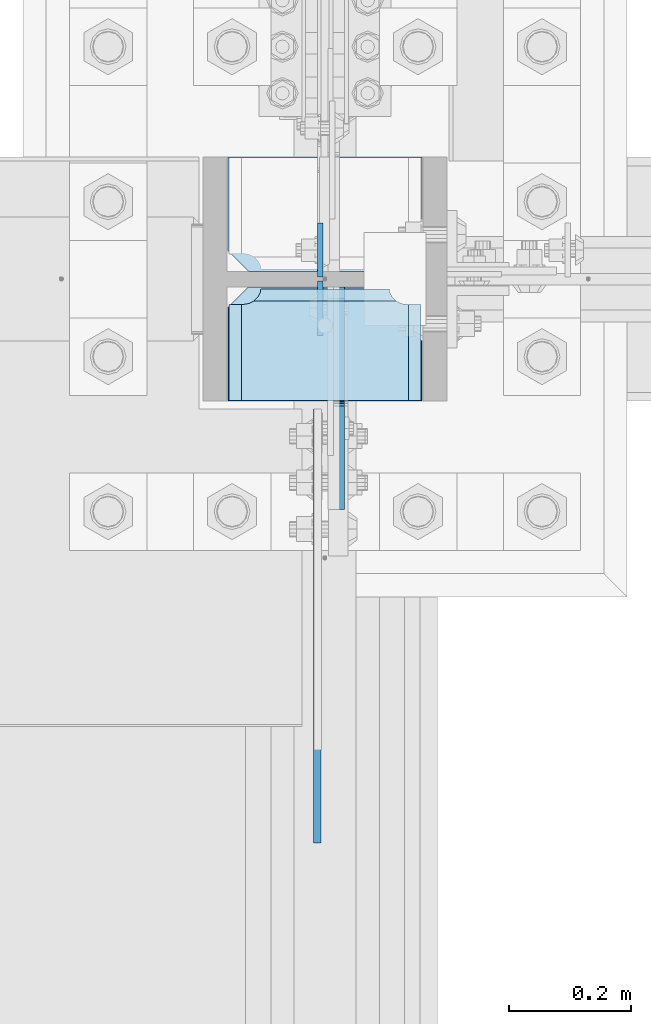
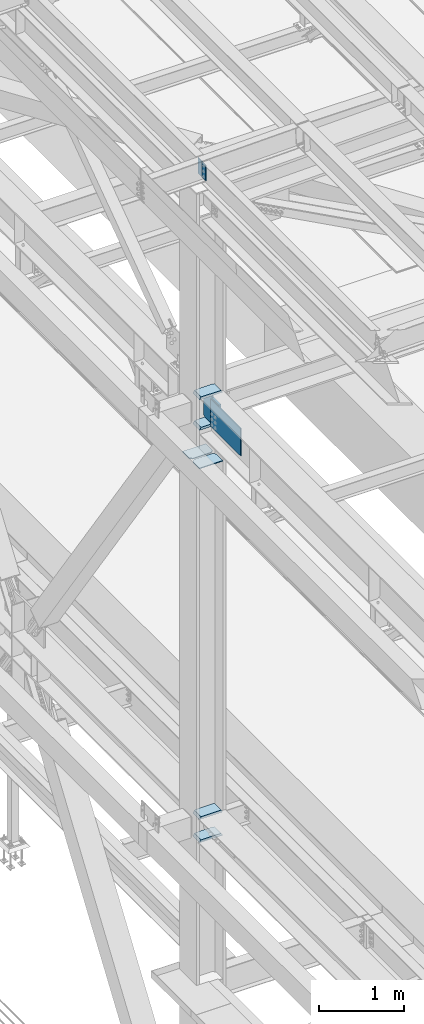
# One storey, part 3248 of 3843: 10 plates, 3 elements without a shape of their own.
"""IFC2X3 building model written with IfcOpenShell, lengths in millimetres."""

from ifc_helpers import new_model, si_unit, frame, origin_with_axes, place, context, subcontext, project, spatial, faceted_brep, material, type_object, element, aggregate, save


model = new_model("IFC2X3")

# Units and contexts
model_context = context("Model", 3, precision=1e-05, world=origin_with_axes())
body_context = subcontext(model_context, "Body", "Model", "MODEL_VIEW")
ifc_project = project(units=[si_unit("LENGTHUNIT", "METRE", prefix="MILLI"), si_unit("AREAUNIT", "SQUARE_METRE"), si_unit("VOLUMEUNIT", "CUBIC_METRE"), si_unit("MASSUNIT", "GRAM", prefix="KILO"), si_unit("TIMEUNIT", "SECOND"), si_unit("PLANEANGLEUNIT", "RADIAN"), si_unit("SOLIDANGLEUNIT", "STERADIAN"), si_unit("THERMODYNAMICTEMPERATUREUNIT", "DEGREE_CELSIUS"), si_unit("LUMINOUSINTENSITYUNIT", "LUMEN")], contexts=[model_context])

# Site, building, storey
site_placement = place(None, origin_with_axes())
site = spatial("IfcSite", under=ifc_project, at=site_placement, CompositionType="ELEMENT")
building_placement = place(site_placement, origin_with_axes())
building = spatial("IfcBuilding", under=site, at=building_placement, Name="Undefined", CompositionType="ELEMENT")
storey_placement = place(building_placement, origin_with_axes())
storey = spatial("IfcBuildingStorey", under=building, at=storey_placement, Name="Undefined", CompositionType="ELEMENT", Elevation=0.0)

# Assembly, plates
assembly_1_placement = place(storey_placement, origin_with_axes())
assembly_1 = element("IfcElementAssembly", 1, at=assembly_1_placement, inside=storey, Name="BEAM", AssemblyPlace="NOTDEFINED", PredefinedType="RIGID_FRAME")
ifc_material = material(Name="STEEL/A572-50")
plate_type_1 = type_object("IfcPlateType", PredefinedType="NOTDEFINED")
plate_1_placement = place(assembly_1_placement, frame((36568.0624999422, 50561.875, 45691.494629366), z_axis=(0.0, 1.0, 0.0), x_axis=(0.0, 0.0, -1.0)))
plate_1 = element("IfcPlate", 2, at=plate_1_placement, type_object=plate_type_1, material=ifc_material, Name="PLATE", context=body_context, shape_type="Brep", body=[
    faceted_brep([(0.0, -4.76249999999709, 0.0), (0.0, -4.76249999999709, 88.9000015258789), (0.0, 4.76249999999709, 88.9000015258789), (0.0, 4.76249999999709, 0.0), (228.600006102781, -4.7625000004191, 88.9000015257589), (228.600006102781, 4.76249999954598, 88.9000015257443), (228.600006103079, -4.7625000004482, 7.27595761418343e-12), (228.600006103079, 4.76249999954598, -7.27595761418343e-12)], [[[0, 1, 2, 3]], [[1, 4, 5, 2]], [[4, 6, 7, 5]], [[6, 0, 3, 7]], [[5, 7, 3, 2]], [[6, 4, 1, 0]]]),
])
plate_2_placement = place(assembly_1_placement, frame((36568.0624999363, 50555.525, 45691.494629366), z_axis=(0.0, -1.0, 0.0), x_axis=(0.0, 0.0, -1.0)))
plate_2 = element("IfcPlate", 3, at=plate_2_placement, type_object=plate_type_1, material=ifc_material, Name="PLATE", context=body_context, shape_type="Brep", body=[
    faceted_brep([(0.0, -4.76249999999709, 0.0), (0.0, -4.76249999999709, 88.9000015258789), (0.0, 4.76249999999709, 88.9000015258789), (0.0, 4.76249999999709, 0.0), (228.600006102781, -4.7625000004191, 88.9000015257589), (228.600006102781, 4.76249999954598, 88.9000015257443), (228.600006103079, -4.7625000004482, 7.27595761418343e-12), (228.600006103079, 4.76249999954598, -7.27595761418343e-12)], [[[0, 1, 2, 3]], [[1, 4, 5, 2]], [[4, 6, 7, 5]], [[6, 0, 3, 7]], [[5, 7, 3, 2]], [[6, 4, 1, 0]]]),
])
aggregate(assembly_1, [plate_1, plate_2])

assembly_2_placement = place(storey_placement, origin_with_axes())
assembly_2 = element("IfcElementAssembly", 4, at=assembly_2_placement, inside=storey, Name="COLUMN", AssemblyPlace="NOTDEFINED", PredefinedType="RIGID_FRAME")
plate_type_2 = type_object("IfcPlateType", PredefinedType="NOTDEFINED")
plate_3_placement = place(assembly_2_placement, frame((36595.0500001907, 50546.0, 42049.7), z_axis=(0.0, -0.707106781186682, 0.707106781186413), x_axis=(0.0, -0.707106781186548, -0.707106781186548)))
plate_3 = element("IfcPlate", 5, at=plate_3_placement, type_object=plate_type_2, material=ifc_material, Name="PLATE", context=body_context, shape_type="Brep", body=[
    faceted_brep([(0.0, -12.6999999999971, 0.0), (-258.182363479558, -12.6999999999971, 258.182363479453), (-258.182363479558, 12.6999999999971, 258.182363479453), (0.0, 12.6999999999971, 0.0), (-258.182363479282, -12.6999999999971, 285.123131842804), (-258.182363479282, 12.6999999999971, 285.123131842804), (-139.193969873246, -12.6999999999971, 404.111525448876), (-139.193969873246, 12.6999999999971, 404.111525448876), (-132.458777647626, -12.6999999999971, 397.376333223259), (-132.458777647626, 12.6999999999971, 397.376333223259), (-128.338601179479, -12.6999999999971, 394.623319322793), (-128.338601179479, 12.6999999999971, 394.623319322793), (-123.478521661425, -12.6999999999971, 393.656589400227), (-123.478521661425, 12.6999999999971, 393.656589400227), (-118.618442143357, -12.6999999999971, 394.623319322851), (-118.618442143357, 12.6999999999971, 394.623319322851), (-114.498265675167, -12.6999999999971, 397.376333223354), (-114.498265675167, 12.6999999999971, 397.376333223354), (2.24506403549458, -12.6999999999971, 514.119662934059), (2.24506403549458, 12.6999999999971, 514.119662934059), (280.633003787327, -12.6999999999971, 235.731723182307), (280.633003787327, 12.6999999999971, 235.731723182307), (154.909418090407, -12.6999999999971, 110.008137485343), (154.909418090407, 12.6999999999971, 110.008137485343), (145.929161969383, -12.6999999999971, 118.98839360636), (145.929161969383, 12.6999999999971, 118.98839360636), (26.9407683630998, -12.7000000000007, 3.63797880709171e-12), (26.9407683630998, 12.7000000000007, 3.63797880709171e-12)], [[[0, 1, 2, 3]], [[1, 4, 5, 2]], [[4, 6, 7, 5]], [[6, 8, 9, 7]], [[8, 10, 11, 9]], [[10, 12, 13, 11]], [[12, 14, 15, 13]], [[14, 16, 17, 15]], [[16, 18, 19, 17]], [[18, 20, 21, 19]], [[20, 22, 23, 21]], [[22, 24, 25, 23]], [[24, 26, 27, 25]], [[26, 0, 3, 27]], [[5, 7, 9, 11, 13, 15, 17, 19, 21, 23, 25, 27, 3, 2]], [[26, 24, 22, 20, 18, 16, 14, 12, 10, 8, 6, 4, 1, 0]]]),
])
plate_type_3 = type_object("IfcPlateType", PredefinedType="NOTDEFINED")
plate_4_placement = place(assembly_2_placement, frame((36736.3375, 50546.0, 42013.1875), z_axis=(-1.0, 0.0, 0.0), x_axis=(0.0, -1.0, 0.0)))
plate_4 = element("IfcPlate", 6, at=plate_4_placement, type_object=plate_type_3, material=ifc_material, Name="PLATE", context=body_context, shape_type="Brep", body=[
    faceted_brep([(16.7959640327026, 6.12986484301655, 270.569839531447), (23.117661231503, 17.0792088240414, 276.89153673024), (23.3389576632762, 17.4625000000015, 277.325855432093), (23.3389576632762, 17.4625000000015, 43.3491445679101), (23.1176612314885, 17.0792088240414, 43.7834632697632), (16.7959640327026, 6.12986484301655, 50.1051604685563), (8.83016085001873, -7.66711346669035, 54.1639399157939), (3.17499995231628, -17.4625000000015, 55.059629409523), (3.17499995231628, -17.4625000000015, 265.61537059048), (8.83016085003328, -7.66711346669035, 266.511060084209), (28.5750007629395, 17.4625000000015, 297.336542336721), (28.5750007629395, -17.4625000000015, 317.500500047689), (186.531300000002, -17.4625000000015, 317.500500047689), (186.531300000002, 17.4625000000015, 297.336542336721), (186.531300000002, 17.4625000000015, 23.3384576632816), (186.531300000002, -17.4625000000015, 3.17449995231436), (28.5750007629395, -17.4625000000015, 3.17449995230709), (28.5750007629395, 17.4625000000015, 23.338457663267), (8.83016085001873, -17.4625000000015, 266.511047877182), (16.7959640327026, -17.4625000000015, 270.56982732442), (23.1176612314885, -17.4625000000015, 276.891524523206), (27.1764406787261, -17.4625000000015, 284.857327705889), (27.1764406787261, 17.4625000000015, 284.857327705889), (28.5750007629395, -17.4625000000015, 293.687488555908), (28.5750007629395, 17.4625000000015, 293.687488555908), (28.5750007629395, -17.4625000000015, 26.9874992370605), (28.5750007629395, 17.4625000000015, 26.9874992370605), (27.1764406787261, -17.4625000000015, 35.8176600870793), (27.1764406787261, 17.4625000000015, 35.8176600870793), (23.1176612314885, -17.4625000000015, 43.7834632697632), (16.7959640327026, -17.4625000000015, 50.105160468549), (8.83016085001873, -17.4625000000015, 54.1639399157866)], [[[0, 1, 2, 3, 4, 5, 6, 7, 8, 9]], [[10, 11, 12, 13]], [[14, 15, 16, 17]], [[18, 9, 8]], [[18, 19, 0, 9]], [[19, 20, 1, 0]], [[20, 21, 22, 2, 1]], [[21, 23, 24, 22]], [[24, 23, 11, 10]], [[15, 14, 13, 12]], [[25, 26, 17, 16]], [[25, 27, 28, 26]], [[28, 27, 29, 4, 3]], [[29, 30, 5, 4]], [[30, 31, 6, 5]], [[31, 7, 6]], [[22, 24, 10, 13, 14, 17, 26, 28, 3, 2]], [[31, 30, 29, 27, 25, 16, 15, 12, 11, 23, 21, 20, 19, 18, 8, 7]]]),
])
plate_5_placement = place(assembly_2_placement, frame((36736.3375, 50546.0, 42451.3375), z_axis=(-1.0, 0.0, 0.0), x_axis=(0.0, -1.0, 0.0)))
plate_5 = element("IfcPlate", 7, at=plate_5_placement, type_object=plate_type_3, material=ifc_material, Name="PLATE", context=body_context, shape_type="Brep", body=[
    faceted_brep([(16.7959640327026, 6.12954035346047, 270.569839531447), (23.117661231503, 17.0792088240414, 276.89153673024), (23.3389576632762, 17.4625000000015, 277.325855432093), (23.3389576632762, 17.4625000000015, 43.3491445679101), (23.1176612314885, 17.0792088240414, 43.7834632697632), (16.7959640327026, 6.12954035346047, 50.1051604685563), (8.83016085001873, -7.6678330078139, 54.1639399157939), (3.17499995231628, -17.4625000000015, 55.059629409523), (3.17499995231628, -17.4625000000015, 265.61537059048), (8.83016085003328, -7.6678330078139, 266.511060084209), (28.5750007629395, 17.4625000000015, 297.336542336721), (28.5750007629395, -17.4625000000015, 317.500500047689), (186.531300000002, -17.4625000000015, 317.500500047689), (186.531300000002, 17.4625000000015, 297.336542336721), (186.531300000002, 17.4625000000015, 23.3384576632816), (186.531300000002, -17.4625000000015, 3.17449995231436), (28.5750007629395, -17.4625000000015, 3.17449995230709), (28.5750007629395, 17.4625000000015, 23.338457663267), (8.83016085001873, -17.4625000000015, 266.511047877182), (16.7959640327026, -17.4625000000015, 270.56982732442), (23.1176612314885, -17.4625000000015, 276.891524523206), (27.1764406787261, -17.4625000000015, 284.857327705889), (27.1764406787261, 17.4625000000015, 284.857327705889), (28.5750007629395, -17.4625000000015, 293.687488555908), (28.5750007629395, 17.4625000000015, 293.687488555908), (28.5750007629395, -17.4625000000015, 26.9874992370605), (28.5750007629395, 17.4625000000015, 26.9874992370605), (27.1764406787261, -17.4625000000015, 35.8176600870793), (27.1764406787261, 17.4625000000015, 35.8176600870793), (23.1176612314885, -17.4625000000015, 43.7834632697632), (16.7959640327026, -17.4625000000015, 50.105160468549), (8.83016085001873, -17.4625000000015, 54.1639399157866)], [[[0, 1, 2, 3, 4, 5, 6, 7, 8, 9]], [[10, 11, 12, 13]], [[14, 15, 16, 17]], [[18, 9, 8]], [[18, 19, 0, 9]], [[19, 20, 1, 0]], [[20, 21, 22, 2, 1]], [[21, 23, 24, 22]], [[24, 23, 11, 10]], [[15, 14, 13, 12]], [[25, 26, 17, 16]], [[25, 27, 28, 26]], [[28, 27, 29, 4, 3]], [[29, 30, 5, 4]], [[30, 31, 6, 5]], [[31, 7, 6]], [[22, 24, 10, 13, 14, 17, 26, 28, 3, 2]], [[31, 30, 29, 27, 25, 16, 15, 12, 11, 23, 21, 20, 19, 18, 8, 7]]]),
])
plate_6_placement = place(assembly_2_placement, frame((36736.3375, 50546.0, 36085.4625), z_axis=(-1.0, 0.0, 0.0), x_axis=(0.0, -1.0, 0.0)))
plate_6 = element("IfcPlate", 8, at=plate_6_placement, type_object=plate_type_3, material=ifc_material, Name="PLATE", context=body_context, shape_type="Brep", body=[
    faceted_brep([(16.7959640327026, 6.1297025982276, 270.569839531447), (23.117661231503, 17.0792088240414, 276.89153673024), (23.3389576632762, 17.4625000000015, 277.325855432093), (23.3389576632762, 17.4625000000015, 43.3491445679101), (23.1176612314885, 17.0792088240414, 43.7834632697632), (16.7959640327026, 6.1297025982276, 50.1051604685563), (8.830160850026, -7.66747323726304, 54.1639399157939), (3.17499995231628, -17.4625000000015, 55.059629409523), (3.17499995231628, -17.4625000000015, 265.61537059048), (8.830160850026, -7.66747323726304, 266.511060084209), (186.531300000002, 17.4625000000015, 23.3384576632816), (186.531300000002, -17.4625000000015, 3.17449995231436), (28.5750007629395, -17.4625000000015, 3.17449995230709), (28.5750007629395, 17.4625000000015, 23.338457663267), (28.5750007629395, 17.4625000000015, 297.336542336721), (28.5750007629395, -17.4625000000015, 317.500500047689), (186.531300000002, -17.4625000000015, 317.500500047689), (186.531300000002, 17.4625000000015, 297.336542336721), (8.83016085001873, -17.4625000000015, 266.511047877182), (16.7959640327026, -17.4625000000015, 270.56982732442), (23.1176612314885, -17.4625000000015, 276.891524523206), (27.1764406787261, -17.4625000000015, 284.857327705889), (27.1764406787261, 17.4625000000015, 284.857327705889), (28.5750007629395, -17.4625000000015, 293.687488555908), (28.5750007629395, 17.4625000000015, 293.687488555908), (28.5750007629395, -17.4625000000015, 26.9874992370605), (28.5750007629395, 17.4625000000015, 26.9874992370605), (27.1764406787261, -17.4625000000015, 35.8176600870793), (27.1764406787261, 17.4625000000015, 35.8176600870793), (23.1176612314885, -17.4625000000015, 43.7834632697632), (16.7959640327026, -17.4625000000015, 50.105160468549), (8.83016085001873, -17.4625000000015, 54.1639399157866)], [[[0, 1, 2, 3, 4, 5, 6, 7, 8, 9]], [[10, 11, 12, 13]], [[14, 15, 16, 17]], [[18, 9, 8]], [[18, 19, 0, 9]], [[19, 20, 1, 0]], [[20, 21, 22, 2, 1]], [[21, 23, 24, 22]], [[24, 23, 15, 14]], [[11, 10, 17, 16]], [[25, 26, 13, 12]], [[25, 27, 28, 26]], [[28, 27, 29, 4, 3]], [[29, 30, 5, 4]], [[30, 31, 6, 5]], [[31, 7, 6]], [[22, 24, 14, 17, 10, 13, 26, 28, 3, 2]], [[31, 30, 29, 27, 25, 12, 11, 16, 15, 23, 21, 20, 19, 18, 8, 7]]]),
])
plate_7_placement = place(assembly_2_placement, frame((36736.3375, 50546.0, 36418.8375), z_axis=(-1.0, 0.0, 0.0), x_axis=(0.0, -1.0, 0.0)))
plate_7 = element("IfcPlate", 9, at=plate_7_placement, type_object=plate_type_3, material=ifc_material, Name="PLATE", context=body_context, shape_type="Brep", body=[
    faceted_brep([(16.7959640327026, 6.1297025982276, 270.569839531447), (23.117661231503, 17.0792088240414, 276.89153673024), (23.3389576632762, 17.4625000000015, 277.325855432093), (23.3389576632762, 17.4625000000015, 43.3491445679101), (23.1176612314885, 17.0792088240414, 43.7834632697632), (16.7959640327026, 6.1297025982276, 50.1051604685563), (8.830160850026, -7.66747323726304, 54.1639399157939), (3.17499995231628, -17.4625000000015, 55.059629409523), (3.17499995231628, -17.4625000000015, 265.61537059048), (8.830160850026, -7.66747323726304, 266.511060084209), (186.531300000002, 17.4625000000015, 23.3384576632816), (186.531300000002, -17.4625000000015, 3.17449995231436), (28.5750007629395, -17.4625000000015, 3.17449995230709), (28.5750007629395, 17.4625000000015, 23.338457663267), (28.5750007629395, 17.4625000000015, 297.336542336721), (28.5750007629395, -17.4625000000015, 317.500500047689), (186.531300000002, -17.4625000000015, 317.500500047689), (186.531300000002, 17.4625000000015, 297.336542336721), (8.83016085001873, -17.4625000000015, 266.511047877182), (16.7959640327026, -17.4625000000015, 270.56982732442), (23.1176612314885, -17.4625000000015, 276.891524523206), (27.1764406787261, -17.4625000000015, 284.857327705889), (27.1764406787261, 17.4625000000015, 284.857327705889), (28.5750007629395, -17.4625000000015, 293.687488555908), (28.5750007629395, 17.4625000000015, 293.687488555908), (28.5750007629395, -17.4625000000015, 26.9874992370605), (28.5750007629395, 17.4625000000015, 26.9874992370605), (27.1764406787261, -17.4625000000015, 35.8176600870793), (27.1764406787261, 17.4625000000015, 35.8176600870793), (23.1176612314885, -17.4625000000015, 43.7834632697632), (16.7959640327026, -17.4625000000015, 50.105160468549), (8.83016085001873, -17.4625000000015, 54.1639399157866)], [[[0, 1, 2, 3, 4, 5, 6, 7, 8, 9]], [[10, 11, 12, 13]], [[14, 15, 16, 17]], [[18, 9, 8]], [[18, 19, 0, 9]], [[19, 20, 1, 0]], [[20, 21, 22, 2, 1]], [[21, 23, 24, 22]], [[24, 23, 15, 14]], [[11, 10, 17, 16]], [[25, 26, 13, 12]], [[25, 27, 28, 26]], [[28, 27, 29, 4, 3]], [[29, 30, 5, 4]], [[30, 31, 6, 5]], [[31, 7, 6]], [[22, 24, 14, 17, 10, 13, 26, 28, 3, 2]], [[31, 30, 29, 27, 25, 12, 11, 16, 15, 23, 21, 20, 19, 18, 8, 7]]]),
])
plate_type_4 = type_object("IfcPlateType", PredefinedType="NOTDEFINED")
plate_8_placement = place(assembly_2_placement, frame((36734.75, 50571.4, 41446.7833494556), z_axis=(0.0, 1.0, 0.0), x_axis=(-1.0, 0.0, 0.0)))
plate_8 = element("IfcPlate", 10, at=plate_8_placement, type_object=plate_type_4, material=ifc_material, Name="CB_COL", context=body_context, shape_type="Brep", body=[
    faceted_brep([(0.0, -6.34999999999854, 33.3375015258789), (0.0, -6.34999999999854, 187.324999999997), (0.0, 6.34999999999854, 187.324999999997), (0.0, 6.34999999999854, 33.3375015258789), (317.5, -6.34999999999854, 187.324999999997), (317.5, 6.34999999999854, 187.324999999997), (317.499999999985, -6.34999999999854, 33.3375015258789), (317.499999999985, 6.34999999999854, 33.3375015258789), (284.162498474107, -6.34999999999854, 0.0), (284.162498474107, 6.34999999999854, 0.0), (33.3375015258789, -6.34999999999854, 0.0), (33.3375015258789, 6.34999999999854, 0.0)], [[[0, 1, 2, 3]], [[1, 4, 5, 2]], [[4, 6, 7, 5]], [[6, 8, 9, 7]], [[8, 10, 11, 9]], [[10, 0, 3, 11]], [[5, 7, 9, 11, 3, 2]], [[10, 8, 6, 4, 1, 0]]]),
])
plate_9_placement = place(assembly_2_placement, frame((36734.75, 50546.0, 41446.7833494556), z_axis=(0.0, -1.0, 0.0), x_axis=(-1.0, 0.0, 0.0)))
plate_9 = element("IfcPlate", 11, at=plate_9_placement, type_object=plate_type_4, material=ifc_material, Name="CB_COL", context=body_context, shape_type="Brep", body=[
    faceted_brep([(0.0, -6.34999999999854, 33.3375015258789), (0.0, -6.34999999999854, 187.324999999997), (0.0, 6.34999999999854, 187.324999999997), (0.0, 6.34999999999854, 33.3375015258789), (317.5, -6.34999999999854, 187.324999999997), (317.5, 6.34999999999854, 187.324999999997), (317.499999999985, -6.34999999999854, 33.3375015258789), (317.499999999985, 6.34999999999854, 33.3375015258789), (284.162498474107, -6.34999999999854, 0.0), (284.162498474107, 6.34999999999854, 0.0), (33.3375015258789, -6.34999999999854, 0.0), (33.3375015258789, 6.34999999999854, 0.0)], [[[0, 1, 2, 3]], [[1, 4, 5, 2]], [[4, 6, 7, 5]], [[6, 8, 9, 7]], [[8, 10, 11, 9]], [[10, 0, 3, 11]], [[5, 7, 9, 11, 3, 2]], [[10, 8, 6, 4, 1, 0]]]),
])
aggregate(assembly_2, [plate_3, plate_4, plate_5, plate_6, plate_7, plate_8, plate_9])

# Assembly, plate
assembly_3_placement = place(storey_placement, origin_with_axes())
assembly_3 = element("IfcElementAssembly", 12, at=assembly_3_placement, inside=storey, Name="BEAM", AssemblyPlace="NOTDEFINED", PredefinedType="RIGID_FRAME")
plate_type_5 = type_object("IfcPlateType", PredefinedType="NOTDEFINED")
plate_10_placement = place(assembly_3_placement, frame((36563.3, 49634.775, 42017.949987793), z_axis=(0.0, 0.0, 1.0), x_axis=(0.0, 1.0, 0.0)))
plate_10 = element("IfcPlate", 13, at=plate_10_placement, type_object=plate_type_5, material=ifc_material, Name="PLATE", context=body_context, shape_type="Brep", body=[
    faceted_brep([(0.0, -6.3499999046162, 0.0), (0.0, -6.34999999999854, 393.700012207031), (0.0, 6.34999999999854, 393.700012207031), (7.27595761418343e-12, 6.3499999046162, 0.0), (711.199999999968, -6.35000000000582, 393.700012207031), (711.200000000012, 6.34999999999854, 393.700000000004), (711.199999999968, -6.35000000000582, 0.0), (711.199999999997, 6.34999999999854, 0.0)], [[[0, 1, 2, 3]], [[1, 4, 5, 2]], [[4, 6, 7, 5]], [[6, 0, 3, 7]], [[7, 3, 2, 5]], [[6, 4, 1, 0]]]),
])
aggregate(assembly_3, [plate_10])

save(model, "model.ifc")
